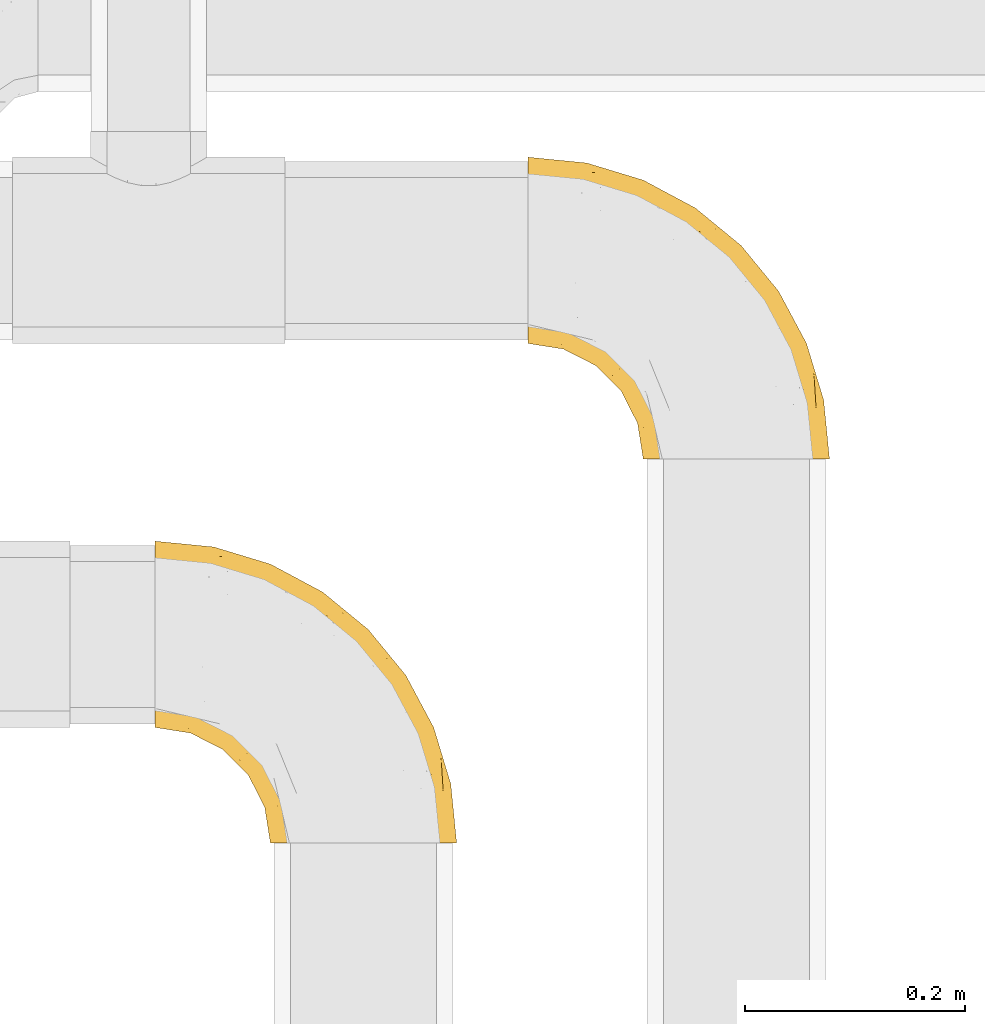
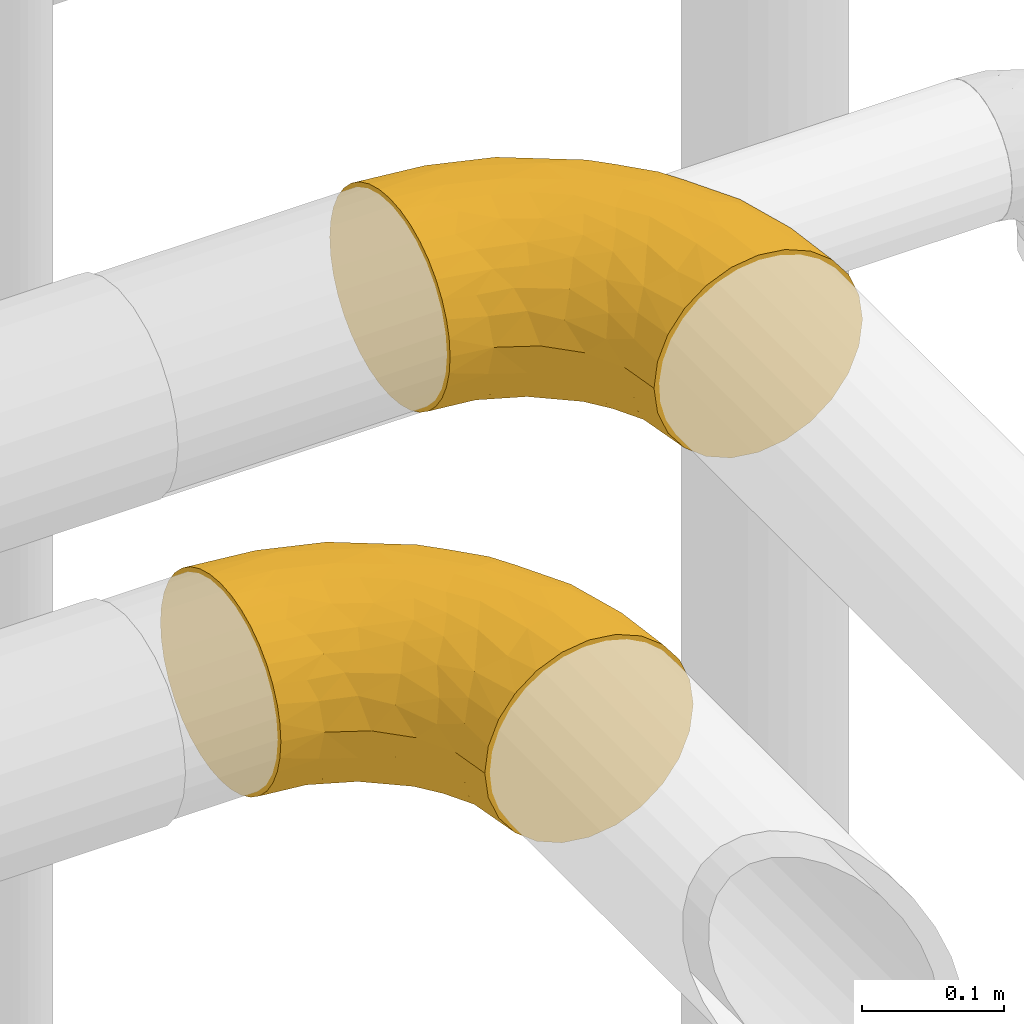
# One storey, part 136 of 827: 2 coverings.
"""IFC2X3 building model written with IfcOpenShell, lengths in millimetres."""

from ifc_helpers import new_model, entity, si_unit, converted_unit, derived_unit, direction, frame, origin, place, context, subcontext, project, spatial, faceted_brep, element, save


model = new_model("IFC2X3")

# Units and contexts
model_context = context("Model", 3, precision=0.01, world=origin(), true_north=direction((6.12303176911189e-17, 1.0)))
body_context = subcontext(model_context, "Body", "Model", "MODEL_VIEW")
ifc_project = project(units=[si_unit("LENGTHUNIT", "METRE", prefix="MILLI"), si_unit("AREAUNIT", "SQUARE_METRE"), si_unit("VOLUMEUNIT", "CUBIC_METRE"), converted_unit("PLANEANGLEUNIT", "DEGREE", entity("IfcRatioMeasure", 0.0174532925199433), si_unit("PLANEANGLEUNIT", "RADIAN"), dimensions=[0, 0, 0, 0, 0, 0, 0]), si_unit("MASSUNIT", "GRAM", prefix="KILO"), derived_unit("MASSDENSITYUNIT", [(si_unit("MASSUNIT", "GRAM", prefix="KILO"), 1), (si_unit("LENGTHUNIT", "METRE"), -3)]), derived_unit("MOMENTOFINERTIAUNIT", [(si_unit("LENGTHUNIT", "METRE"), 4)]), si_unit("TIMEUNIT", "SECOND"), si_unit("FREQUENCYUNIT", "HERTZ"), si_unit("THERMODYNAMICTEMPERATUREUNIT", "DEGREE_CELSIUS"), derived_unit("THERMALTRANSMITTANCEUNIT", [(si_unit("MASSUNIT", "GRAM", prefix="KILO"), 1), (si_unit("THERMODYNAMICTEMPERATUREUNIT", "KELVIN"), -1), (si_unit("TIMEUNIT", "SECOND"), -3)]), derived_unit("VOLUMETRICFLOWRATEUNIT", [(si_unit("LENGTHUNIT", "METRE"), 3), (si_unit("TIMEUNIT", "SECOND"), -1)]), derived_unit("MASSFLOWRATEUNIT", [(si_unit("MASSUNIT", "GRAM", prefix="KILO"), 1), (si_unit("TIMEUNIT", "SECOND"), -1)]), derived_unit("ROTATIONALFREQUENCYUNIT", [(si_unit("TIMEUNIT", "SECOND"), -1)]), si_unit("ELECTRICCURRENTUNIT", "AMPERE"), si_unit("ELECTRICVOLTAGEUNIT", "VOLT"), si_unit("POWERUNIT", "WATT"), si_unit("FORCEUNIT", "NEWTON", prefix="KILO"), si_unit("ILLUMINANCEUNIT", "LUX"), si_unit("LUMINOUSFLUXUNIT", "LUMEN"), si_unit("LUMINOUSINTENSITYUNIT", "CANDELA"), derived_unit("USERDEFINED", [(si_unit("MASSUNIT", "GRAM", prefix="KILO"), -1), (si_unit("LENGTHUNIT", "METRE"), -2), (si_unit("TIMEUNIT", "SECOND"), 3), (si_unit("LUMINOUSFLUXUNIT", "LUMEN"), 1)]), derived_unit("LINEARVELOCITYUNIT", [(si_unit("LENGTHUNIT", "METRE"), 1), (si_unit("TIMEUNIT", "SECOND"), -1)]), si_unit("PRESSUREUNIT", "PASCAL"), derived_unit("USERDEFINED", [(si_unit("LENGTHUNIT", "METRE"), -2), (si_unit("MASSUNIT", "GRAM", prefix="KILO"), 1), (si_unit("TIMEUNIT", "SECOND"), -2)]), derived_unit("LINEARFORCEUNIT", [(si_unit("MASSUNIT", "GRAM", prefix="KILO"), 1), (si_unit("LENGTHUNIT", "METRE"), 1), (si_unit("TIMEUNIT", "SECOND"), -2), (si_unit("LENGTHUNIT", "METRE"), -1)]), derived_unit("PLANARFORCEUNIT", [(si_unit("MASSUNIT", "GRAM", prefix="KILO"), 1), (si_unit("LENGTHUNIT", "METRE"), 1), (si_unit("TIMEUNIT", "SECOND"), -2), (si_unit("LENGTHUNIT", "METRE"), -2)])], contexts=[model_context])

# Site, building, storey
site_placement = place(None, origin())
site = spatial("IfcSite", under=ifc_project, at=site_placement, CompositionType="ELEMENT")
building_placement = place(site_placement, origin())
building = spatial("IfcBuilding", under=site, at=building_placement, CompositionType="ELEMENT")
storey_placement = place(building_placement, frame((0.0, 0.0, 28200.0)))
storey = spatial("IfcBuildingStorey", under=building, at=storey_placement, Name="08", CompositionType="ELEMENT", Elevation=28200.0)

# Coverings
covering_1_placement = place(storey_placement, frame((21983.16, 14558.2, 2713.55)))
element("IfcCovering", 1, at=covering_1_placement, inside=storey, Name=":ADSK_", ObjectType=":ADSK_", PredefinedType="INSULATION", context=body_context, shape_type="Brep", body=[
    faceted_brep([(1.6, 220.62, 166.18), (1.6, 234.03, 159.92), (1.6, 246.14, 151.44), (1.6, 256.6, 140.98), (1.6, 265.08, 128.87), (1.6, 271.33, 115.47), (1.6, 275.16, 101.18), (1.6, 276.45, 86.45), (1.6, 275.16, 71.71), (1.6, 271.33, 57.42), (1.6, 265.07, 44.02), (1.6, 256.59, 31.9), (1.6, 246.13, 21.44), (1.6, 234.02, 12.96), (1.6, 220.62, 6.71), (1.6, 206.33, 2.88), (1.6, 191.6, 1.6), (1.6, 176.86, 2.89), (1.6, 162.57, 6.71), (1.6, 149.17, 12.97), (1.6, 137.05, 21.45), (1.6, 126.59, 31.91), (1.6, 118.11, 44.02), (1.6, 111.86, 57.42), (1.6, 108.03, 71.71), (1.6, 106.75, 86.45), (1.6, 108.04, 101.18), (1.6, 111.86, 115.47), (1.6, 118.12, 128.88), (1.6, 126.6, 140.99), (1.6, 137.06, 151.45), (1.6, 149.17, 159.93), (1.6, 162.57, 166.18), (1.6, 176.86, 170.01), (1.6, 191.6, 171.3), (1.6, 206.33, 170.01), (131.6, 1.6, 26.45), (149.17, 1.6, 12.96), (169.63, 1.6, 4.49), (191.6, 1.6, 1.6), (213.56, 1.6, 4.49), (234.02, 1.6, 12.96), (251.59, 1.6, 26.45), (265.08, 1.6, 44.02), (273.55, 1.6, 64.48), (276.45, 1.6, 86.45), (273.55, 1.6, 108.41), (265.08, 1.6, 128.87), (251.59, 1.6, 146.44), (234.02, 1.6, 159.93), (213.56, 1.6, 168.4), (191.6, 1.6, 171.3), (169.63, 1.6, 168.4), (149.17, 1.6, 159.93), (131.6, 1.6, 146.44), (118.11, 1.6, 128.87), (109.64, 1.6, 108.41), (106.75, 1.6, 86.45), (109.64, 1.6, 64.48), (118.11, 1.6, 44.02), (262.36, 78.36, 108.89), (271.16, 55.22, 86.45), (255.52, 106.78, 86.45), (50.98, 227.56, 160.57), (172.61, 210.93, 113.84), (203.97, 166.54, 132.78), (212.76, 169.48, 115.35), (195.94, 195.94, 86.45), (169.94, 121.35, 169.66), (120.06, 150.14, 171.3), (135.1, 135.1, 171.3), (150.14, 120.06, 171.3), (237.65, 124.32, 124.06), (241.63, 130.67, 106.11), (58.66, 210.57, 167.01), (229.96, 93.72, 149.97), (211.71, 139.64, 145.0), (192.74, 144.17, 156.09), (230.12, 154.29, 86.45), (158.59, 208.4, 134.92), (110.39, 240.3, 130.81), (119.11, 221.79, 146.85), (154.29, 230.12, 86.45), (62.72, 262.33, 120.3), (111.17, 248.26, 114.99), (79.56, 263.49, 102.82), (253.1, 63.94, 135.66), (235.85, 108.29, 137.97), (195.66, 79.35, 169.13), (241.79, 42.69, 152.15), (55.22, 271.16, 86.45), (106.78, 255.52, 86.45), (217.39, 76.62, 162.08), (99.75, 212.49, 159.81), (264.19, 49.07, 122.41), (186.11, 126.68, 164.65), (153.25, 177.19, 160.16), (177.64, 177.64, 147.45), (119.88, 179.24, 168.0), (172.78, 84.03, 171.3), (84.03, 172.78, 171.3), (62.89, 246.43, 143.95), (186.83, 43.87, 171.3), (43.87, 186.83, 171.3), (113.05, 35.25, 128.7), (100.5, 55.06, 120.84), (106.86, 29.97, 111.79), (163.63, 40.1, 167.99), (25.67, 174.11, 169.81), (62.91, 141.82, 162.83), (91.14, 151.41, 169.87), (66.45, 162.23, 169.62), (106.25, 68.19, 139.83), (117.34, 78.22, 154.11), (94.43, 94.43, 147.7), (85.43, 83.32, 129.83), (32.15, 106.07, 111.24), (57.82, 95.5, 113.13), (52.87, 105.97, 128.47), (135.69, 106.13, 168.91), (127.24, 90.7, 163.29), (150.81, 84.2, 169.04), (86.66, 63.4, 86.45), (96.24, 50.79, 102.42), (78.07, 78.07, 108.81), (142.05, 30.53, 157.36), (122.04, 42.81, 143.61), (71.57, 119.66, 152.9), (88.75, 127.3, 162.78), (34.09, 101.6, 86.45), (63.4, 86.66, 86.45), (117.23, 132.44, 169.89), (114.56, 114.56, 165.72), (43.38, 118.77, 140.27), (26.96, 113.91, 126.4), (101.6, 34.09, 86.45), (38.85, 159.75, 166.71), (67.12, 108.44, 141.38), (28.1, 145.49, 159.19), (106.51, 101.13, 158.14), (36.78, 131.96, 151.08), (137.5, 64.62, 161.17), (78.07, 78.07, 64.08), (186.83, 43.87, 1.6), (163.63, 40.1, 4.9), (172.78, 84.03, 1.6), (106.86, 29.97, 61.1), (96.24, 50.79, 70.47), (25.67, 174.1, 3.08), (100.5, 55.06, 52.05), (113.05, 35.25, 44.19), (57.82, 95.5, 59.77), (85.44, 83.31, 43.07), (106.25, 68.19, 33.07), (52.86, 105.97, 44.43), (67.12, 108.44, 31.51), (142.05, 30.53, 15.53), (122.04, 42.81, 29.28), (137.5, 64.63, 11.72), (32.15, 106.07, 61.65), (150.8, 84.21, 3.85), (150.14, 120.06, 1.6), (66.45, 162.23, 3.27), (43.87, 186.83, 1.6), (84.03, 172.78, 1.6), (71.57, 119.66, 19.99), (36.79, 131.95, 21.82), (62.92, 141.81, 10.07), (26.95, 113.91, 46.49), (88.75, 127.29, 10.11), (35.6, 145.35, 12.88), (43.38, 118.77, 32.63), (127.23, 90.7, 9.6), (135.68, 106.13, 3.98), (135.1, 135.1, 1.6), (117.33, 78.22, 18.78), (38.86, 159.75, 6.18), (91.14, 151.41, 3.02), (120.06, 150.14, 1.6), (117.23, 132.44, 3.0), (114.56, 114.56, 7.17), (106.5, 101.13, 14.75), (94.43, 94.43, 25.19), (195.66, 79.35, 3.76), (169.94, 121.35, 3.23), (186.11, 126.68, 8.24), (262.36, 78.36, 64.0), (58.66, 210.57, 5.88), (99.75, 212.49, 13.07), (153.26, 177.18, 12.73), (119.88, 179.23, 4.89), (119.11, 221.79, 26.04), (212.77, 169.48, 57.54), (217.39, 76.62, 10.82), (255.51, 82.71, 49.85), (253.1, 63.94, 37.23), (235.86, 108.29, 34.92), (241.79, 42.69, 20.74), (229.96, 93.72, 22.92), (172.61, 210.93, 59.05), (111.17, 248.25, 57.9), (177.64, 177.64, 25.44), (158.58, 208.4, 37.97), (237.65, 124.32, 48.83), (241.63, 130.67, 66.78), (211.71, 139.64, 27.89), (62.72, 262.33, 52.59), (203.97, 166.55, 40.11), (62.88, 246.43, 28.94), (50.99, 227.55, 12.32), (192.75, 144.16, 16.8), (79.56, 263.49, 70.06), (110.39, 240.3, 42.07)], [[[0, 1, 2, 3, 4, 5, 6, 7, 8, 9, 10, 11, 12, 13, 14, 15, 16, 17, 18, 19, 20, 21, 22, 23, 24, 25, 26, 27, 28, 29, 30, 31, 32, 33, 34, 35]], [[36, 37, 38, 39, 40, 41, 42, 43, 44, 45, 46, 47, 48, 49, 50, 51, 52, 53, 54, 55, 56, 57, 58, 59]], [[60, 61, 62]], [[61, 46, 45]], [[63, 2, 1]], [[64, 65, 66]], [[64, 66, 67]], [[68, 69, 70, 71]], [[72, 73, 66]], [[74, 0, 35]], [[75, 76, 77]], [[78, 73, 62]], [[79, 80, 81]], [[64, 67, 82]], [[83, 84, 85]], [[86, 48, 47]], [[65, 76, 87]], [[51, 50, 88]], [[75, 89, 86]], [[90, 85, 91]], [[75, 77, 92]], [[74, 93, 63]], [[94, 46, 60]], [[95, 68, 88]], [[96, 97, 81]], [[96, 93, 98]], [[88, 68, 99]], [[98, 100, 69]], [[83, 101, 80]], [[101, 63, 81]], [[48, 89, 49]], [[79, 65, 64]], [[85, 6, 5]], [[101, 83, 3]], [[50, 92, 88]], [[83, 85, 5]], [[94, 86, 47]], [[3, 83, 4]], [[75, 87, 76]], [[90, 7, 6]], [[88, 99, 102]], [[101, 3, 2]], [[100, 98, 74]], [[100, 74, 103]], [[4, 83, 5]], [[34, 103, 35]], [[51, 88, 102]], [[85, 84, 91]], [[72, 86, 94]], [[81, 80, 101]], [[103, 74, 35]], [[98, 69, 68]], [[98, 93, 74]], [[74, 63, 0]], [[63, 101, 2]], [[50, 49, 92]], [[46, 61, 60]], [[84, 82, 91]], [[89, 92, 49]], [[95, 88, 92]], [[6, 85, 90]], [[83, 80, 84]], [[96, 81, 93]], [[79, 81, 97]], [[65, 79, 97]], [[64, 80, 79]], [[76, 65, 97]], [[65, 72, 66]], [[80, 64, 84]], [[82, 84, 64]], [[73, 72, 60]], [[67, 66, 78]], [[62, 73, 60]], [[78, 66, 73]], [[98, 95, 96]], [[77, 96, 95]], [[98, 68, 95]], [[99, 68, 71]], [[63, 93, 81]], [[0, 63, 1]], [[77, 76, 97]], [[75, 86, 87]], [[96, 77, 97]], [[77, 95, 92]], [[86, 72, 87]], [[65, 87, 72]], [[86, 89, 48]], [[92, 89, 75]], [[46, 94, 47]], [[72, 94, 60]], [[104, 105, 106]], [[52, 51, 102]], [[52, 102, 107]], [[33, 108, 103]], [[109, 110, 111]], [[112, 113, 114]], [[114, 115, 112]], [[99, 107, 102]], [[116, 117, 118]], [[119, 120, 121]], [[122, 123, 124]], [[53, 125, 54]], [[125, 126, 54]], [[127, 128, 109]], [[26, 129, 116]], [[130, 122, 124]], [[131, 132, 119]], [[57, 56, 106]], [[133, 28, 134]], [[106, 105, 123]], [[122, 135, 123]], [[132, 120, 119]], [[28, 133, 29]], [[121, 107, 99]], [[103, 108, 111]], [[107, 53, 52]], [[115, 124, 105]], [[136, 32, 31]], [[117, 129, 130]], [[34, 33, 103]], [[133, 137, 127]], [[136, 31, 138]], [[139, 114, 113]], [[32, 108, 33]], [[127, 114, 139]], [[30, 140, 138]], [[129, 26, 25]], [[134, 116, 118]], [[54, 126, 55]], [[126, 112, 104]], [[27, 26, 116]], [[116, 134, 27]], [[140, 30, 29]], [[117, 130, 124]], [[131, 119, 70]], [[109, 140, 127]], [[109, 136, 138]], [[118, 117, 115]], [[127, 140, 133]], [[110, 131, 69]], [[32, 136, 108]], [[125, 107, 141]], [[111, 108, 136]], [[105, 104, 112]], [[115, 114, 137]], [[107, 125, 53]], [[126, 125, 141]], [[105, 112, 115]], [[113, 126, 141]], [[126, 113, 112]], [[120, 113, 141]], [[135, 57, 106]], [[124, 123, 105]], [[135, 106, 123]], [[104, 56, 55]], [[56, 104, 106]], [[55, 126, 104]], [[120, 141, 121]], [[139, 120, 132]], [[107, 121, 141]], [[71, 121, 99]], [[121, 71, 119]], [[119, 71, 70]], [[70, 69, 131]], [[110, 69, 100]], [[131, 110, 128]], [[111, 110, 100]], [[110, 109, 128]], [[117, 116, 129]], [[115, 117, 124]], [[120, 139, 113]], [[139, 132, 128]], [[133, 134, 118]], [[27, 134, 28]], [[133, 118, 137]], [[29, 133, 140]], [[115, 137, 118]], [[114, 127, 137]], [[103, 111, 100]], [[109, 111, 136]], [[139, 128, 127]], [[128, 132, 131]], [[30, 138, 31]], [[109, 138, 140]], [[122, 130, 142]], [[143, 144, 145]], [[57, 135, 146]], [[146, 135, 147]], [[17, 148, 18]], [[149, 150, 146]], [[142, 149, 147]], [[122, 147, 135]], [[130, 129, 151]], [[150, 58, 146]], [[149, 152, 153]], [[154, 155, 152]], [[37, 144, 38]], [[39, 38, 143]], [[37, 36, 156]], [[156, 157, 158]], [[159, 154, 151]], [[144, 143, 38]], [[145, 160, 161]], [[36, 59, 157]], [[162, 163, 164]], [[165, 166, 167]], [[154, 159, 168]], [[162, 148, 163]], [[129, 25, 24]], [[169, 165, 167]], [[170, 20, 19]], [[168, 23, 22]], [[171, 21, 166]], [[160, 158, 172]], [[161, 173, 174]], [[165, 155, 171]], [[151, 129, 159]], [[20, 166, 21]], [[175, 172, 158]], [[170, 176, 167]], [[177, 178, 179]], [[179, 173, 180]], [[162, 164, 177]], [[152, 149, 142]], [[170, 167, 166]], [[171, 154, 168]], [[17, 16, 163]], [[129, 24, 159]], [[165, 169, 181]], [[17, 163, 148]], [[176, 19, 18]], [[153, 175, 157]], [[160, 144, 158]], [[23, 159, 24]], [[171, 155, 154]], [[156, 144, 37]], [[176, 18, 148]], [[152, 142, 151]], [[153, 152, 182]], [[157, 156, 36]], [[144, 156, 158]], [[175, 153, 182]], [[153, 157, 150]], [[181, 175, 182]], [[157, 175, 158]], [[142, 147, 122]], [[146, 147, 149]], [[153, 150, 149]], [[146, 58, 57]], [[157, 59, 150]], [[58, 150, 59]], [[181, 172, 175]], [[172, 173, 160]], [[172, 180, 173]], [[144, 160, 145]], [[179, 178, 174]], [[161, 160, 173]], [[177, 164, 178]], [[179, 169, 177]], [[173, 179, 174]], [[169, 179, 180]], [[162, 167, 176]], [[152, 151, 154]], [[130, 151, 142]], [[165, 181, 182]], [[172, 181, 180]], [[23, 168, 159]], [[22, 21, 171]], [[171, 168, 22]], [[165, 171, 166]], [[165, 182, 155]], [[152, 155, 182]], [[167, 162, 177]], [[162, 176, 148]], [[177, 169, 167]], [[181, 169, 180]], [[20, 170, 166]], [[19, 176, 170]], [[183, 184, 185]], [[43, 186, 44]], [[61, 44, 186]], [[183, 39, 143]], [[145, 161, 184]], [[62, 61, 186]], [[187, 164, 163]], [[188, 189, 190]], [[188, 191, 189]], [[178, 190, 184]], [[192, 67, 78]], [[193, 183, 185]], [[194, 43, 195]], [[195, 196, 194]], [[61, 45, 44]], [[40, 193, 41]], [[41, 197, 42]], [[197, 193, 198]], [[82, 199, 200]], [[201, 191, 202]], [[42, 197, 195]], [[203, 192, 204]], [[15, 187, 163]], [[62, 186, 204]], [[195, 43, 42]], [[190, 185, 184]], [[190, 178, 164]], [[196, 198, 205]], [[206, 10, 9]], [[205, 201, 207]], [[163, 16, 15]], [[14, 187, 15]], [[12, 208, 209]], [[39, 183, 40]], [[208, 12, 11]], [[205, 210, 201]], [[185, 210, 193]], [[13, 209, 14]], [[188, 190, 187]], [[206, 211, 200]], [[82, 67, 199]], [[208, 11, 206]], [[203, 207, 192]], [[90, 91, 211]], [[191, 188, 209]], [[206, 11, 10]], [[211, 8, 90]], [[9, 8, 211]], [[7, 90, 8]], [[191, 208, 212]], [[191, 209, 208]], [[208, 206, 212]], [[200, 212, 206]], [[145, 183, 143]], [[193, 40, 183]], [[188, 187, 209]], [[187, 190, 164]], [[202, 207, 201]], [[91, 82, 200]], [[211, 206, 9]], [[202, 191, 212]], [[189, 191, 201]], [[212, 199, 202]], [[199, 192, 207]], [[199, 207, 202]], [[195, 198, 196]], [[200, 211, 91]], [[199, 212, 200]], [[67, 192, 199]], [[204, 186, 194]], [[192, 78, 204]], [[62, 204, 78]], [[210, 189, 201]], [[185, 190, 189]], [[145, 184, 183]], [[184, 161, 174, 178]], [[14, 209, 187]], [[209, 13, 12]], [[196, 207, 203]], [[198, 193, 210]], [[198, 210, 205]], [[189, 210, 185]], [[207, 196, 205]], [[194, 196, 203]], [[193, 197, 41]], [[195, 197, 198]], [[204, 194, 203]], [[43, 194, 186]]]),
])
covering_2_placement = place(storey_placement, frame((21643.51, 14208.4, 2713.54)))
element("IfcCovering", 2, at=covering_2_placement, inside=storey, Name=":ADSK_", ObjectType=":ADSK_", PredefinedType="INSULATION", context=body_context, shape_type="Brep", body=[
    faceted_brep([(1.6, 220.62, 166.18), (1.6, 234.03, 159.92), (1.6, 246.14, 151.44), (1.6, 256.6, 140.98), (1.6, 265.08, 128.87), (1.6, 271.33, 115.47), (1.6, 275.16, 101.18), (1.6, 276.45, 86.45), (1.6, 275.16, 71.71), (1.6, 271.33, 57.42), (1.6, 265.07, 44.02), (1.6, 256.59, 31.9), (1.6, 246.13, 21.44), (1.6, 234.02, 12.96), (1.6, 220.62, 6.71), (1.6, 206.33, 2.88), (1.6, 191.6, 1.6), (1.6, 176.86, 2.89), (1.6, 162.57, 6.71), (1.6, 149.17, 12.97), (1.6, 137.05, 21.45), (1.6, 126.59, 31.91), (1.6, 118.11, 44.02), (1.6, 111.86, 57.42), (1.6, 108.03, 71.71), (1.6, 106.75, 86.45), (1.6, 108.04, 101.18), (1.6, 111.86, 115.47), (1.6, 118.12, 128.88), (1.6, 126.6, 140.99), (1.6, 137.06, 151.45), (1.6, 149.17, 159.93), (1.6, 162.57, 166.18), (1.6, 176.86, 170.01), (1.6, 191.6, 171.3), (1.6, 206.33, 170.01), (131.6, 1.6, 26.45), (149.17, 1.6, 12.96), (169.63, 1.6, 4.49), (191.6, 1.6, 1.6), (213.56, 1.6, 4.49), (234.02, 1.6, 12.96), (251.59, 1.6, 26.45), (265.08, 1.6, 44.02), (273.55, 1.6, 64.48), (276.45, 1.6, 86.45), (273.55, 1.6, 108.41), (265.08, 1.6, 128.87), (251.59, 1.6, 146.44), (234.02, 1.6, 159.93), (213.56, 1.6, 168.4), (191.6, 1.6, 171.3), (169.63, 1.6, 168.4), (149.17, 1.6, 159.93), (131.6, 1.6, 146.44), (118.11, 1.6, 128.87), (109.64, 1.6, 108.41), (106.75, 1.6, 86.45), (109.64, 1.6, 64.48), (118.11, 1.6, 44.02), (262.36, 78.36, 108.89), (271.16, 55.22, 86.45), (255.52, 106.78, 86.45), (50.98, 227.56, 160.57), (172.61, 210.93, 113.84), (203.97, 166.54, 132.78), (212.76, 169.48, 115.35), (195.94, 195.94, 86.45), (169.94, 121.35, 169.66), (120.06, 150.14, 171.3), (135.1, 135.1, 171.3), (150.14, 120.06, 171.3), (237.65, 124.32, 124.06), (241.63, 130.67, 106.11), (58.66, 210.57, 167.01), (229.96, 93.72, 149.97), (211.71, 139.64, 145.0), (192.74, 144.17, 156.09), (230.12, 154.29, 86.45), (158.59, 208.4, 134.92), (110.39, 240.3, 130.81), (119.11, 221.79, 146.85), (154.29, 230.12, 86.45), (62.72, 262.33, 120.3), (111.17, 248.26, 114.99), (79.56, 263.49, 102.82), (253.1, 63.94, 135.66), (235.85, 108.29, 137.97), (195.66, 79.35, 169.13), (241.79, 42.69, 152.15), (55.22, 271.16, 86.45), (106.78, 255.52, 86.45), (217.39, 76.62, 162.08), (99.75, 212.49, 159.81), (264.19, 49.07, 122.41), (186.11, 126.68, 164.65), (153.25, 177.19, 160.16), (177.64, 177.64, 147.45), (119.88, 179.24, 168.0), (172.78, 84.03, 171.3), (84.03, 172.78, 171.3), (62.89, 246.43, 143.95), (186.83, 43.87, 171.3), (43.87, 186.83, 171.3), (113.05, 35.25, 128.7), (100.5, 55.06, 120.84), (106.86, 29.97, 111.79), (163.63, 40.1, 167.99), (25.67, 174.11, 169.81), (62.91, 141.82, 162.83), (91.14, 151.41, 169.87), (66.45, 162.23, 169.62), (106.25, 68.19, 139.83), (117.34, 78.22, 154.11), (94.43, 94.43, 147.7), (85.43, 83.32, 129.83), (32.15, 106.07, 111.24), (57.82, 95.5, 113.13), (52.87, 105.97, 128.47), (135.69, 106.13, 168.91), (127.24, 90.7, 163.29), (150.81, 84.2, 169.04), (86.66, 63.4, 86.45), (96.24, 50.79, 102.42), (78.07, 78.07, 108.81), (142.05, 30.53, 157.36), (122.04, 42.81, 143.61), (71.57, 119.66, 152.9), (88.75, 127.3, 162.78), (34.09, 101.6, 86.45), (63.4, 86.66, 86.45), (117.23, 132.44, 169.89), (43.38, 118.77, 140.27), (26.96, 113.91, 126.4), (101.6, 34.09, 86.45), (114.56, 114.56, 165.72), (38.85, 159.75, 166.71), (67.12, 108.44, 141.38), (28.1, 145.49, 159.19), (106.51, 101.13, 158.14), (36.78, 131.96, 151.08), (137.5, 64.62, 161.17), (78.07, 78.07, 64.08), (186.83, 43.87, 1.6), (163.63, 40.1, 4.9), (172.78, 84.03, 1.6), (106.86, 29.97, 61.1), (96.24, 50.79, 70.47), (25.67, 174.1, 3.08), (100.5, 55.06, 52.05), (113.05, 35.25, 44.19), (57.82, 95.5, 59.77), (85.44, 83.31, 43.07), (106.25, 68.19, 33.07), (52.86, 105.97, 44.43), (67.12, 108.44, 31.51), (142.05, 30.53, 15.53), (122.04, 42.81, 29.28), (137.5, 64.63, 11.72), (32.15, 106.07, 61.65), (150.8, 84.21, 3.85), (150.14, 120.06, 1.6), (66.45, 162.23, 3.27), (43.87, 186.83, 1.6), (84.03, 172.78, 1.6), (71.57, 119.66, 19.99), (36.79, 131.95, 21.82), (62.92, 141.81, 10.07), (26.95, 113.91, 46.49), (88.75, 127.29, 10.11), (35.6, 145.35, 12.88), (43.38, 118.77, 32.63), (127.23, 90.7, 9.6), (135.68, 106.13, 3.98), (135.1, 135.1, 1.6), (117.33, 78.22, 18.78), (38.86, 159.75, 6.18), (91.14, 151.41, 3.02), (120.06, 150.14, 1.6), (117.23, 132.44, 3.0), (114.56, 114.56, 7.17), (106.5, 101.13, 14.75), (94.43, 94.43, 25.19), (195.66, 79.35, 3.76), (169.94, 121.35, 3.23), (186.11, 126.68, 8.24), (262.36, 78.36, 64.0), (58.66, 210.57, 5.88), (99.75, 212.49, 13.07), (153.26, 177.18, 12.73), (119.88, 179.23, 4.89), (119.11, 221.79, 26.04), (212.77, 169.48, 57.54), (217.39, 76.62, 10.82), (255.51, 82.71, 49.85), (253.1, 63.94, 37.23), (235.86, 108.29, 34.92), (241.79, 42.69, 20.74), (229.96, 93.72, 22.92), (172.61, 210.93, 59.05), (111.17, 248.25, 57.9), (177.64, 177.64, 25.44), (158.58, 208.4, 37.97), (237.65, 124.32, 48.83), (241.63, 130.67, 66.78), (211.71, 139.64, 27.89), (62.72, 262.33, 52.59), (203.97, 166.55, 40.11), (62.88, 246.43, 28.94), (50.99, 227.55, 12.32), (192.75, 144.16, 16.8), (79.56, 263.49, 70.06), (110.39, 240.3, 42.07)], [[[0, 1, 2, 3, 4, 5, 6, 7, 8, 9, 10, 11, 12, 13, 14, 15, 16, 17, 18, 19, 20, 21, 22, 23, 24, 25, 26, 27, 28, 29, 30, 31, 32, 33, 34, 35]], [[36, 37, 38, 39, 40, 41, 42, 43, 44, 45, 46, 47, 48, 49, 50, 51, 52, 53, 54, 55, 56, 57, 58, 59]], [[60, 61, 62]], [[61, 46, 45]], [[63, 2, 1]], [[64, 65, 66]], [[64, 66, 67]], [[68, 69, 70, 71]], [[72, 73, 66]], [[74, 0, 35]], [[75, 76, 77]], [[78, 73, 62]], [[79, 80, 81]], [[64, 67, 82]], [[83, 84, 85]], [[86, 48, 47]], [[65, 76, 87]], [[51, 50, 88]], [[75, 89, 86]], [[90, 85, 91]], [[75, 77, 92]], [[74, 93, 63]], [[94, 46, 60]], [[95, 68, 88]], [[96, 97, 81]], [[96, 93, 98]], [[88, 68, 99]], [[98, 100, 69]], [[83, 101, 80]], [[101, 63, 81]], [[48, 89, 49]], [[79, 65, 64]], [[85, 6, 5]], [[101, 83, 3]], [[50, 92, 88]], [[83, 85, 5]], [[94, 86, 47]], [[3, 83, 4]], [[75, 87, 76]], [[90, 7, 6]], [[88, 99, 102]], [[101, 3, 2]], [[100, 98, 74]], [[100, 74, 103]], [[4, 83, 5]], [[34, 103, 35]], [[51, 88, 102]], [[85, 84, 91]], [[72, 86, 94]], [[81, 80, 101]], [[103, 74, 35]], [[98, 69, 68]], [[98, 93, 74]], [[74, 63, 0]], [[63, 101, 2]], [[50, 49, 92]], [[46, 61, 60]], [[84, 82, 91]], [[89, 92, 49]], [[95, 88, 92]], [[6, 85, 90]], [[83, 80, 84]], [[96, 81, 93]], [[79, 81, 97]], [[65, 79, 97]], [[64, 80, 79]], [[76, 65, 97]], [[65, 72, 66]], [[80, 64, 84]], [[82, 84, 64]], [[73, 72, 60]], [[67, 66, 78]], [[62, 73, 60]], [[78, 66, 73]], [[98, 95, 96]], [[77, 96, 95]], [[98, 68, 95]], [[99, 68, 71]], [[63, 93, 81]], [[0, 63, 1]], [[77, 76, 97]], [[75, 86, 87]], [[96, 77, 97]], [[77, 95, 92]], [[86, 72, 87]], [[65, 87, 72]], [[86, 89, 48]], [[92, 89, 75]], [[46, 94, 47]], [[72, 94, 60]], [[104, 105, 106]], [[52, 51, 102]], [[52, 102, 107]], [[33, 108, 103]], [[109, 110, 111]], [[112, 113, 114]], [[114, 115, 112]], [[99, 107, 102]], [[116, 117, 118]], [[119, 120, 121]], [[122, 123, 124]], [[53, 125, 54]], [[125, 126, 54]], [[127, 128, 109]], [[26, 129, 116]], [[130, 122, 124]], [[128, 131, 110]], [[57, 56, 106]], [[132, 28, 133]], [[106, 105, 123]], [[122, 134, 123]], [[135, 120, 119]], [[28, 132, 29]], [[121, 107, 99]], [[103, 108, 111]], [[107, 53, 52]], [[115, 124, 105]], [[136, 32, 31]], [[117, 129, 130]], [[34, 33, 103]], [[132, 137, 127]], [[136, 31, 138]], [[139, 114, 113]], [[32, 108, 33]], [[127, 114, 139]], [[30, 140, 138]], [[129, 26, 25]], [[133, 116, 118]], [[54, 126, 55]], [[126, 112, 104]], [[27, 26, 116]], [[116, 133, 27]], [[140, 30, 29]], [[117, 130, 124]], [[131, 119, 70]], [[109, 140, 127]], [[109, 136, 138]], [[118, 117, 115]], [[127, 140, 132]], [[110, 131, 69]], [[32, 136, 108]], [[125, 107, 141]], [[111, 108, 136]], [[105, 104, 112]], [[115, 114, 137]], [[107, 125, 53]], [[126, 125, 141]], [[105, 112, 115]], [[113, 126, 141]], [[126, 113, 112]], [[120, 113, 141]], [[134, 57, 106]], [[124, 123, 105]], [[134, 106, 123]], [[104, 56, 55]], [[56, 104, 106]], [[55, 126, 104]], [[120, 141, 121]], [[139, 120, 135]], [[107, 121, 141]], [[71, 121, 99]], [[121, 71, 119]], [[119, 71, 70]], [[131, 70, 69]], [[69, 100, 110]], [[119, 131, 135]], [[111, 110, 100]], [[110, 109, 128]], [[117, 116, 129]], [[115, 117, 124]], [[120, 139, 113]], [[139, 135, 128]], [[132, 133, 118]], [[27, 133, 28]], [[132, 118, 137]], [[29, 132, 140]], [[115, 137, 118]], [[114, 127, 137]], [[103, 111, 100]], [[109, 111, 136]], [[139, 128, 127]], [[128, 135, 131]], [[30, 138, 31]], [[109, 138, 140]], [[122, 130, 142]], [[143, 144, 145]], [[57, 134, 146]], [[146, 134, 147]], [[17, 148, 18]], [[149, 150, 146]], [[142, 149, 147]], [[122, 147, 134]], [[130, 129, 151]], [[150, 58, 146]], [[149, 152, 153]], [[154, 155, 152]], [[37, 144, 38]], [[39, 38, 143]], [[37, 36, 156]], [[156, 157, 158]], [[159, 154, 151]], [[144, 143, 38]], [[145, 160, 161]], [[36, 59, 157]], [[162, 163, 164]], [[165, 166, 167]], [[154, 159, 168]], [[162, 148, 163]], [[129, 25, 24]], [[169, 165, 167]], [[170, 20, 19]], [[168, 23, 22]], [[171, 21, 166]], [[160, 158, 172]], [[161, 173, 174]], [[165, 155, 171]], [[151, 129, 159]], [[20, 166, 21]], [[175, 172, 158]], [[170, 176, 167]], [[177, 178, 179]], [[179, 173, 180]], [[162, 164, 177]], [[152, 149, 142]], [[170, 167, 166]], [[171, 154, 168]], [[17, 16, 163]], [[129, 24, 159]], [[165, 169, 181]], [[17, 163, 148]], [[176, 19, 18]], [[153, 175, 157]], [[160, 144, 158]], [[23, 159, 24]], [[171, 155, 154]], [[156, 144, 37]], [[176, 18, 148]], [[152, 142, 151]], [[153, 152, 182]], [[157, 156, 36]], [[144, 156, 158]], [[175, 153, 182]], [[153, 157, 150]], [[181, 175, 182]], [[157, 175, 158]], [[142, 147, 122]], [[146, 147, 149]], [[153, 150, 149]], [[146, 58, 57]], [[157, 59, 150]], [[58, 150, 59]], [[181, 172, 175]], [[172, 173, 160]], [[172, 180, 173]], [[144, 160, 145]], [[174, 173, 179]], [[161, 160, 173]], [[174, 179, 178]], [[179, 169, 177]], [[178, 177, 164]], [[169, 179, 180]], [[162, 167, 176]], [[152, 151, 154]], [[130, 151, 142]], [[165, 181, 182]], [[172, 181, 180]], [[23, 168, 159]], [[22, 21, 171]], [[171, 168, 22]], [[165, 171, 166]], [[165, 182, 155]], [[152, 155, 182]], [[167, 162, 177]], [[162, 176, 148]], [[177, 169, 167]], [[181, 169, 180]], [[20, 170, 166]], [[19, 176, 170]], [[183, 184, 185]], [[43, 186, 44]], [[61, 44, 186]], [[183, 39, 143]], [[145, 161, 184]], [[62, 61, 186]], [[187, 164, 163]], [[188, 189, 190]], [[188, 191, 189]], [[178, 190, 184]], [[192, 67, 78]], [[193, 183, 185]], [[194, 43, 195]], [[195, 196, 194]], [[61, 45, 44]], [[40, 193, 41]], [[41, 197, 42]], [[197, 193, 198]], [[82, 199, 200]], [[201, 191, 202]], [[42, 197, 195]], [[203, 192, 204]], [[15, 187, 163]], [[62, 186, 204]], [[195, 43, 42]], [[190, 185, 184]], [[190, 178, 164]], [[196, 198, 205]], [[206, 10, 9]], [[205, 201, 207]], [[163, 16, 15]], [[14, 187, 15]], [[12, 208, 209]], [[39, 183, 40]], [[208, 12, 11]], [[205, 210, 201]], [[185, 210, 193]], [[13, 209, 14]], [[188, 190, 187]], [[206, 211, 200]], [[82, 67, 199]], [[208, 11, 206]], [[203, 207, 192]], [[90, 91, 211]], [[191, 188, 209]], [[206, 11, 10]], [[211, 8, 90]], [[9, 8, 211]], [[7, 90, 8]], [[191, 208, 212]], [[191, 209, 208]], [[208, 206, 212]], [[200, 212, 206]], [[145, 183, 143]], [[193, 40, 183]], [[188, 187, 209]], [[187, 190, 164]], [[202, 207, 201]], [[91, 82, 200]], [[211, 206, 9]], [[202, 191, 212]], [[189, 191, 201]], [[212, 199, 202]], [[199, 192, 207]], [[199, 207, 202]], [[195, 198, 196]], [[200, 211, 91]], [[199, 212, 200]], [[67, 192, 199]], [[204, 186, 194]], [[192, 78, 204]], [[62, 204, 78]], [[210, 189, 201]], [[185, 190, 189]], [[145, 184, 183]], [[184, 161, 174, 178]], [[14, 209, 187]], [[209, 13, 12]], [[196, 207, 203]], [[198, 193, 210]], [[198, 210, 205]], [[189, 210, 185]], [[207, 196, 205]], [[194, 196, 203]], [[193, 197, 41]], [[195, 197, 198]], [[204, 194, 203]], [[43, 194, 186]]]),
])

save(model, "model.ifc")
